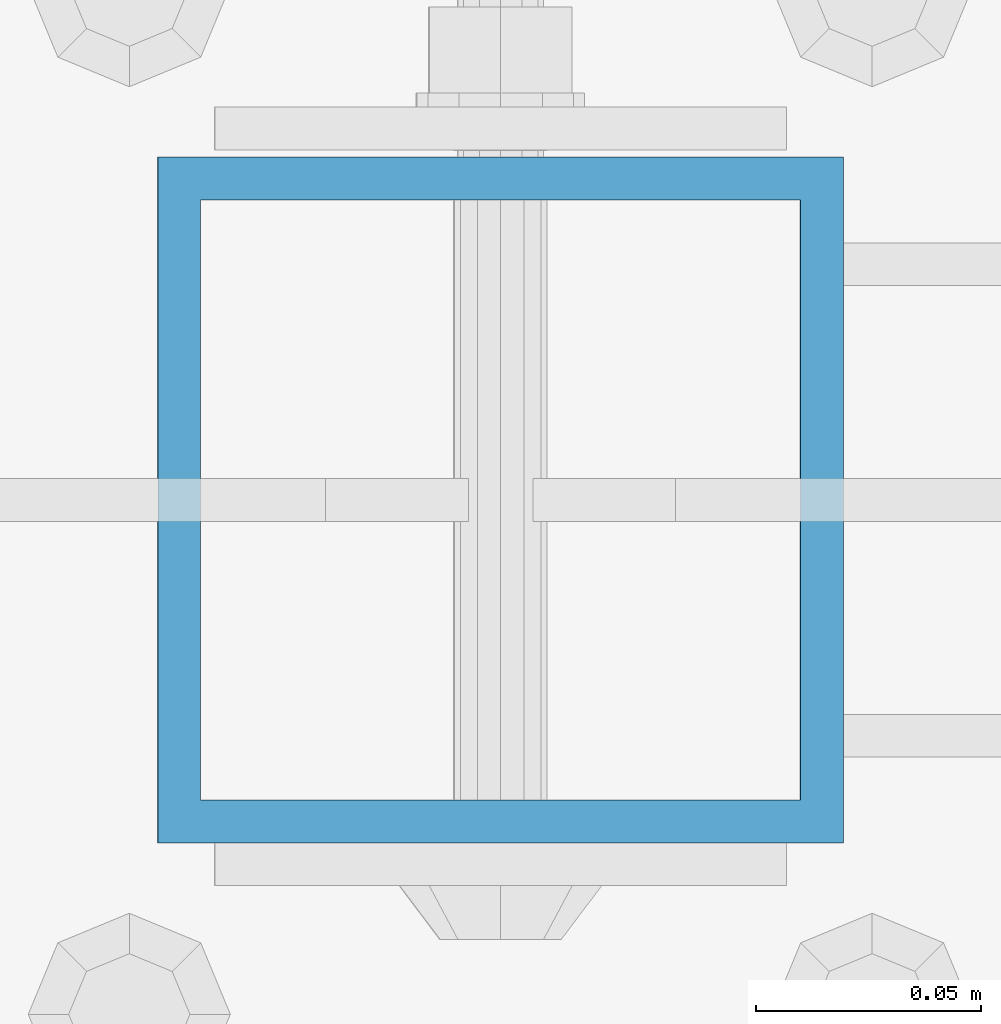
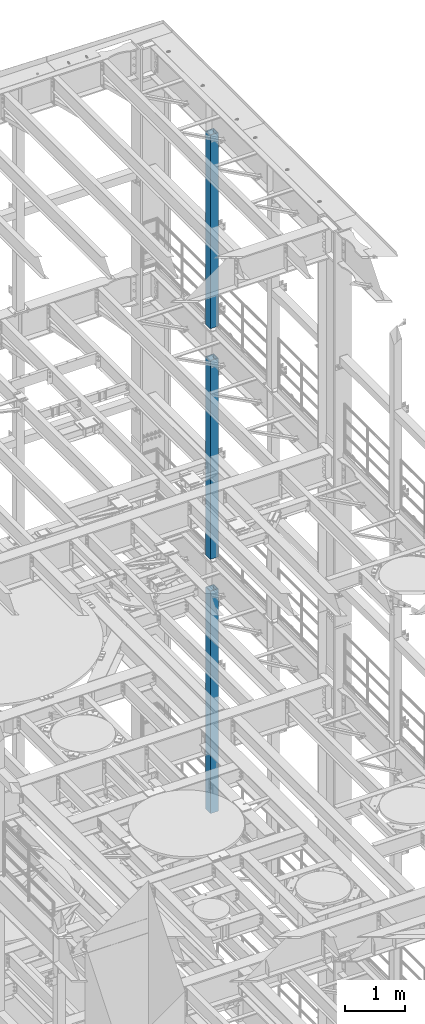
# One storey, part 768 of 1876: 3 columns, 3 elements without a shape of their own.
"""IFC2X3 building model written with IfcOpenShell, lengths in millimetres."""

import ifcopenshell
import ifcopenshell.guid

model = None  # the IFC model being written
_history = None  # IfcOwnerHistory: only IFC2X3 demands one
_inside = {}  # id of a spatial element -> (the spatial element, [elements in it])
_under = {}  # id of a project, library or spatial element -> (it, [spatial elements below it])
_declared = {}  # id of a project -> (the project, [libraries it declares])
_typed = {}  # id of a type object -> (the type object, [elements of that type])
_made_of = {}  # id of a material, layer set ... -> (it, [elements and type objects made of it])


def new_model(schema):
    """Start an empty IFC model of exactly this schema.

    Asked for "IFC4X3", IfcOpenShell would pick the latest addendum, in which some entities
    have other attributes; the version numbers below select the first issue.
    IFC2X3 requires an IfcOwnerHistory on every rooted entity: one is made here for all.
    """
    global model, _history
    if schema == "IFC4X3":
        model = ifcopenshell.file(schema_version=(4, 3, 0, 0))
    else:
        model = ifcopenshell.file(schema=schema)
    _inside.clear()
    _under.clear()
    _declared.clear()
    _typed.clear()
    _made_of.clear()
    _history = None
    if model.schema == "IFC2X3":
        org = make("IfcOrganization", Name="unknown")
        user = make(
            "IfcPersonAndOrganization",
            ThePerson=make("IfcPerson", FamilyName="unknown"),
            TheOrganization=org,
        )
        app = make(
            "IfcApplication",
            ApplicationDeveloper=org,
            Version="unknown",
            ApplicationFullName="unknown",
            ApplicationIdentifier="unknown",
        )
        _history = make(
            "IfcOwnerHistory",
            OwningUser=user,
            OwningApplication=app,
            ChangeAction="ADDED",
            CreationDate=0,
        )
    return model


def make(cls, **values):
    """One entity of the class cls with the attributes given. An attribute that is None is left unset."""
    return model.create_entity(
        cls, **{name: value for name, value in values.items() if value is not None}
    )


def rooted(cls, **values):
    """An entity with a GlobalId (a new one), such as an element, a storey or a relation."""
    return make(cls, GlobalId=ifcopenshell.guid.new(), OwnerHistory=_history, **values)


def si_unit(unit_type, name, prefix=None):
    """IfcSIUnit, for example si_unit("LENGTHUNIT", "METRE", prefix="MILLI")."""
    return make("IfcSIUnit", UnitType=unit_type, Prefix=prefix, Name=name)


def assignment(units):
    """IfcUnitAssignment: the units of a project."""
    return None if units is None else make("IfcUnitAssignment", Units=units)


def point(xyz):
    """IfcCartesianPoint."""
    return None if xyz is None else make("IfcCartesianPoint", Coordinates=xyz)


def direction(xyz):
    """IfcDirection."""
    return None if xyz is None else make("IfcDirection", DirectionRatios=xyz)


def frame(location, z_axis=None, x_axis=None):
    """IfcAxis2Placement3D, a coordinate frame: its origin and axes. An axis left out is left unset."""
    return make(
        "IfcAxis2Placement3D",
        Location=point(location),
        Axis=direction(z_axis),
        RefDirection=direction(x_axis),
    )


def origin_with_axes():
    """The frame at (0, 0, 0) with the z axis (0, 0, 1) and the x axis (1, 0, 0) written out."""
    return frame((0.0, 0.0, 0.0), z_axis=(0.0, 0.0, 1.0), x_axis=(1.0, 0.0, 0.0))


def place(relative_to, where):
    """IfcLocalPlacement: puts the frame where relative to a parent placement (None: the world)."""
    return make(
        "IfcLocalPlacement", PlacementRelTo=relative_to, RelativePlacement=where
    )


def context(
    kind, dimensions, precision=None, world=None, true_north=None, identifier=None
):
    """IfcGeometricRepresentationContext, for example the 3D "Model" context."""
    return make(
        "IfcGeometricRepresentationContext",
        ContextIdentifier=identifier,
        ContextType=kind,
        CoordinateSpaceDimension=dimensions,
        Precision=precision,
        WorldCoordinateSystem=world,
        TrueNorth=true_north,
    )


def subcontext(parent, identifier, kind, view, scale=None):
    """IfcGeometricRepresentationSubContext, for example "Body" below "Model"."""
    return make(
        "IfcGeometricRepresentationSubContext",
        ContextIdentifier=identifier,
        ContextType=kind,
        ParentContext=parent,
        TargetScale=scale,
        TargetView=view,
    )


def project(units=None, contexts=None):
    """IfcProject with its units and contexts."""
    return rooted(
        "IfcProject",
        Name="project",
        RepresentationContexts=contexts,
        UnitsInContext=assignment(units),
    )


def spatial(cls, under=None, at=None, **own):
    """A site, building, storey or space (cls), placed at a placement, below another one or the project."""
    s = rooted(cls, ObjectPlacement=at, **own)
    if under is not None:
        _under.setdefault(under.id(), (under, []))[1].append(s)
    return s


def faces_of(points, faces, orient=None, outer=None):
    """IfcFace entities. A face is a list of loops; a loop is a list of indices into points, from 0.

    orient and outer hold one flag for each loop. By default every Orientation is true, the
    first loop of a face is its IfcFaceOuterBound and the others are IfcFaceBound.
    """
    made = []
    for i, loops in enumerate(faces):
        bounds = []
        for j, loop in enumerate(loops):
            is_outer = j == 0 if outer is None else outer[i][j]
            bounds.append(
                make(
                    "IfcFaceOuterBound" if is_outer else "IfcFaceBound",
                    Bound=make("IfcPolyLoop", Polygon=[points[k] for k in loop]),
                    Orientation=True if orient is None else orient[i][j],
                )
            )
        made.append(make("IfcFace", Bounds=bounds))
    return made


def faceted_brep(points, faces, orient=None, outer=None, voids=None):
    """IfcFacetedBrep: a solid bounded by flat faces; with voids (closed shells), ...WithVoids."""
    shared = [point(p) for p in points]
    hull = make("IfcClosedShell", CfsFaces=faces_of(shared, faces, orient, outer))
    if voids is None:
        return make("IfcFacetedBrep", Outer=hull)
    return make(
        "IfcFacetedBrepWithVoids",
        Outer=hull,
        Voids=[
            make(cls, CfsFaces=faces_of(shared, fs, o, b)) for cls, fs, o, b in voids
        ],
    )


def shape(context_of_items, identifier, shape_type, items):
    """IfcShapeRepresentation: the items that make up one representation, for example the "Body"."""
    return make(
        "IfcShapeRepresentation",
        ContextOfItems=context_of_items,
        RepresentationIdentifier=identifier,
        RepresentationType=shape_type,
        Items=items,
    )


def material(Name=None, Category=None):
    """IfcMaterial."""
    return make("IfcMaterial", Name=Name, Category=Category)


def made_of(thing, what):
    """Note that an element or type object is made of a material, layer set ...; save() writes the relation."""
    if what is not None:
        _made_of.setdefault(what.id(), (what, []))[1].append(thing)
    return thing


def type_object(cls, material=None, **own):
    """A type object (cls), such as IfcWallType, which elements share."""
    return made_of(rooted(cls, **own), material)


def element(
    cls,
    number,
    at=None,
    inside=None,
    cuts=None,
    type_object=None,
    material=None,
    context=None,
    identifier="Body",
    shape_type=None,
    held_by="IfcProductDefinitionShape",
    body=None,
    shapes=None,
    **own,
):
    """One element of the class cls, such as IfcWall. Its Tag is "e" and its number.

    at: its placement. inside: the storey or other place that contains it. cuts: it is an
    opening in that element (IfcRelVoidsElement). A single representation is given by context,
    identifier, shape_type and body (its items); several are given by shapes. held_by: the class
    of the entity that holds the representations. save() writes the other relations.
    """
    e = rooted(cls, Tag="e%d" % number, ObjectPlacement=at, **own)
    if body is not None:
        shapes = [shape(context, identifier, shape_type, body)]
    if shapes is not None:
        e.Representation = make(held_by, Representations=shapes)
    if inside is not None:
        _inside.setdefault(inside.id(), (inside, []))[1].append(e)
    if cuts is not None:
        rooted(
            "IfcRelVoidsElement", RelatingBuildingElement=cuts, RelatedOpeningElement=e
        )
    if type_object is not None:
        _typed.setdefault(type_object.id(), (type_object, []))[1].append(e)
    return made_of(e, material)


def aggregate(whole, parts):
    """IfcRelAggregates: a whole, such as a stair, and the parts it consists of."""
    return rooted("IfcRelAggregates", RelatingObject=whole, RelatedObjects=parts)


def save(model, path):
    """Write the relations noted so far, then the file.

    IfcRelAggregates (storeys below a building ...), IfcRelContainedInSpatialStructure (elements
    in a storey), IfcRelDefinesByType, IfcRelAssociatesMaterial and IfcRelDeclares: one each for
    every whole, place, type object, material and project.
    """
    for whole, parts in _under.values():
        aggregate(whole, parts)
    for where, things in _inside.values():
        rooted(
            "IfcRelContainedInSpatialStructure",
            RelatedElements=things,
            RelatingStructure=where,
        )
    for kind, things in _typed.values():
        rooted("IfcRelDefinesByType", RelatedObjects=things, RelatingType=kind)
    for what, things in _made_of.values():
        rooted("IfcRelAssociatesMaterial", RelatedObjects=things, RelatingMaterial=what)
    for by, libraries in _declared.values():
        rooted("IfcRelDeclares", RelatingContext=by, RelatedDefinitions=libraries)
    model.write(path)


model = new_model("IFC2X3")

# Units and contexts
model_context = context("Model", 3, precision=1e-05, world=origin_with_axes())
body_context = subcontext(model_context, "Body", "Model", "MODEL_VIEW")
ifc_project = project(units=[si_unit("LENGTHUNIT", "METRE", prefix="MILLI"), si_unit("AREAUNIT", "SQUARE_METRE"), si_unit("VOLUMEUNIT", "CUBIC_METRE"), si_unit("MASSUNIT", "GRAM", prefix="KILO"), si_unit("TIMEUNIT", "SECOND"), si_unit("PLANEANGLEUNIT", "RADIAN"), si_unit("SOLIDANGLEUNIT", "STERADIAN"), si_unit("THERMODYNAMICTEMPERATUREUNIT", "DEGREE_CELSIUS"), si_unit("LUMINOUSINTENSITYUNIT", "LUMEN")], contexts=[model_context])

# Site, building, storey
site_placement = place(None, origin_with_axes())
site = spatial("IfcSite", under=ifc_project, at=site_placement, CompositionType="ELEMENT")
building_placement = place(site_placement, origin_with_axes())
building = spatial("IfcBuilding", under=site, at=building_placement, Name="Undefined", CompositionType="ELEMENT")
storey_placement = place(building_placement, origin_with_axes())
storey = spatial("IfcBuildingStorey", under=building, at=storey_placement, Name="Undefined", CompositionType="ELEMENT", Elevation=0.0)

# Assembly, column
assembly_1_placement = place(storey_placement, origin_with_axes())
assembly_1 = element("IfcElementAssembly", 1, at=assembly_1_placement, inside=storey, Name="BEAM", AssemblyPlace="NOTDEFINED", PredefinedType="RIGID_FRAME")
ifc_material = material()
column_type = type_object("IfcColumnType", Name="HSS6X6X3/8", PredefinedType="NOTDEFINED")
column_1_placement = place(assembly_1_placement, frame((7620.0, 11684.0, 17983.2), z_axis=(-1.0, 0.0, 0.0), x_axis=(0.0, 0.0, 1.0)))
column_1 = element("IfcColumn", 2, at=column_1_placement, type_object=column_type, material=ifc_material, Name="COLUMN", ObjectType="HSS6X6X3/8", context=body_context, shape_type="Brep", body=[
    faceted_brep([(12.7000000000016, 66.6750000000002, -66.6750000000002), (12.7000000000016, -66.6750000000002, -66.6750000000002), (3937.0, -66.6750000000002, -66.675), (3937.0, 66.6750000000002, -66.675), (12.7000000000016, -66.6750000000002, 66.6750000000002), (3937.0, -66.6750000000002, 66.675), (12.7000000000016, 66.6750000000002, 66.6750000000002), (3937.0, 66.6750000000002, 66.675), (12.7000000000016, 76.1999999999998, -76.1999999999998), (12.7000000000016, 76.1999999999998, 76.1999999999998), (3937.0, 76.1999999999998, 76.2), (3937.0, 76.1999999999998, -76.2), (12.7000000000016, -76.1999999999998, 76.1999999999998), (3937.0, -76.1999999999998, 76.2), (12.7000000000016, -76.1999999999998, -76.1999999999998), (3937.0, -76.1999999999998, -76.2)], [[[0, 1, 2, 3]], [[1, 4, 5, 2]], [[4, 6, 7, 5]], [[6, 0, 3, 7]], [[8, 9, 10, 11]], [[9, 12, 13, 10]], [[12, 14, 15, 13]], [[14, 8, 11, 15]], [[13, 15, 11, 10], [5, 7, 3, 2]], [[14, 12, 9, 8], [6, 4, 1, 0]]]),
])
aggregate(assembly_1, [column_1])

assembly_2_placement = place(storey_placement, origin_with_axes())
assembly_2 = element("IfcElementAssembly", 3, at=assembly_2_placement, inside=storey, Name="BEAM", AssemblyPlace="NOTDEFINED", PredefinedType="RIGID_FRAME")
column_2_placement = place(assembly_2_placement, frame((7620.0, 11684.0, 13309.6), z_axis=(-1.0, 0.0, 0.0), x_axis=(0.0, 0.0, 1.0)))
column_2 = element("IfcColumn", 4, at=column_2_placement, type_object=column_type, material=ifc_material, Name="COLUMN", ObjectType="HSS6X6X3/8", context=body_context, shape_type="Brep", body=[
    faceted_brep([(12.7000000000016, 66.6750000000002, -66.6750000000002), (12.7000000000016, -66.6750000000002, -66.6750000000002), (4038.6, -66.6750000000002, -66.675), (4038.6, 66.6750000000002, -66.675), (12.7000000000016, -66.6750000000002, 66.6750000000002), (4038.6, -66.6750000000002, 66.675), (12.7000000000016, 66.6750000000002, 66.6750000000002), (4038.6, 66.6750000000002, 66.675), (12.7000000000016, 76.1999999999998, -76.1999999999998), (12.7000000000016, 76.1999999999998, 76.1999999999998), (4038.6, 76.1999999999998, 76.2), (4038.6, 76.1999999999998, -76.2), (12.7000000000016, -76.1999999999998, 76.1999999999998), (4038.6, -76.1999999999998, 76.2), (12.7000000000016, -76.1999999999998, -76.1999999999998), (4038.6, -76.1999999999998, -76.2)], [[[0, 1, 2, 3]], [[1, 4, 5, 2]], [[4, 6, 7, 5]], [[6, 0, 3, 7]], [[8, 9, 10, 11]], [[9, 12, 13, 10]], [[12, 14, 15, 13]], [[14, 8, 11, 15]], [[13, 15, 11, 10], [5, 7, 3, 2]], [[14, 12, 9, 8], [6, 4, 1, 0]]]),
])
aggregate(assembly_2, [column_2])

assembly_3_placement = place(storey_placement, origin_with_axes())
assembly_3 = element("IfcElementAssembly", 5, at=assembly_3_placement, inside=storey, Name="BEAM", AssemblyPlace="NOTDEFINED", PredefinedType="RIGID_FRAME")
column_3_placement = place(assembly_3_placement, frame((7620.0, 11684.0, 8153.4), z_axis=(-0.999999999563517, 0.0, -2.95459999870218e-05), x_axis=(-2.95459999861759e-05, 0.0, 0.999999999563517)))
column_3 = element("IfcColumn", 6, at=column_3_placement, type_object=column_type, material=ifc_material, Name="COLUMN", ObjectType="HSS6X6X3/8", context=body_context, shape_type="Brep", body=[
    faceted_brep([(12.698030025992, 66.6750000000002, -66.675), (12.698030025992, -66.6750000000002, -66.675), (4521.2007045434, -66.6750000000002, -66.675), (4521.2007045434, 66.6750000000002, -66.675), (12.7019699850925, -66.6750000000002, 66.675), (4521.20070454334, -66.6750000000002, 66.675), (12.7019699850925, 66.6750000000002, 66.675), (4521.20070454334, 66.6750000000002, 66.675), (12.6977486003425, 76.1999999999998, -76.2), (12.7022514107421, 76.1999999999998, 76.2), (4521.20070454334, 76.1999999999998, 76.2), (4521.2007045434, 76.1999999999998, -76.2), (12.7022514107421, -76.1999999999998, 76.2), (4521.20070454334, -76.1999999999998, 76.2), (12.6977486003425, -76.1999999999998, -76.2), (4521.2007045434, -76.1999999999998, -76.2)], [[[0, 1, 2, 3]], [[1, 4, 5, 2]], [[4, 6, 7, 5]], [[6, 0, 3, 7]], [[8, 9, 10, 11]], [[9, 12, 13, 10]], [[12, 14, 15, 13]], [[14, 8, 11, 15]], [[13, 15, 11, 10], [5, 7, 3, 2]], [[14, 12, 9, 8], [6, 4, 1, 0]]]),
])
aggregate(assembly_3, [column_3])

save(model, "model.ifc")
